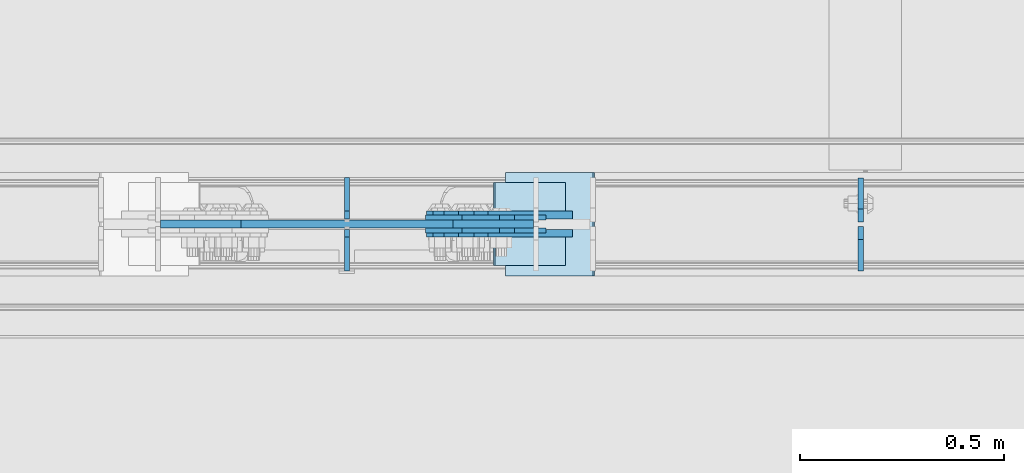
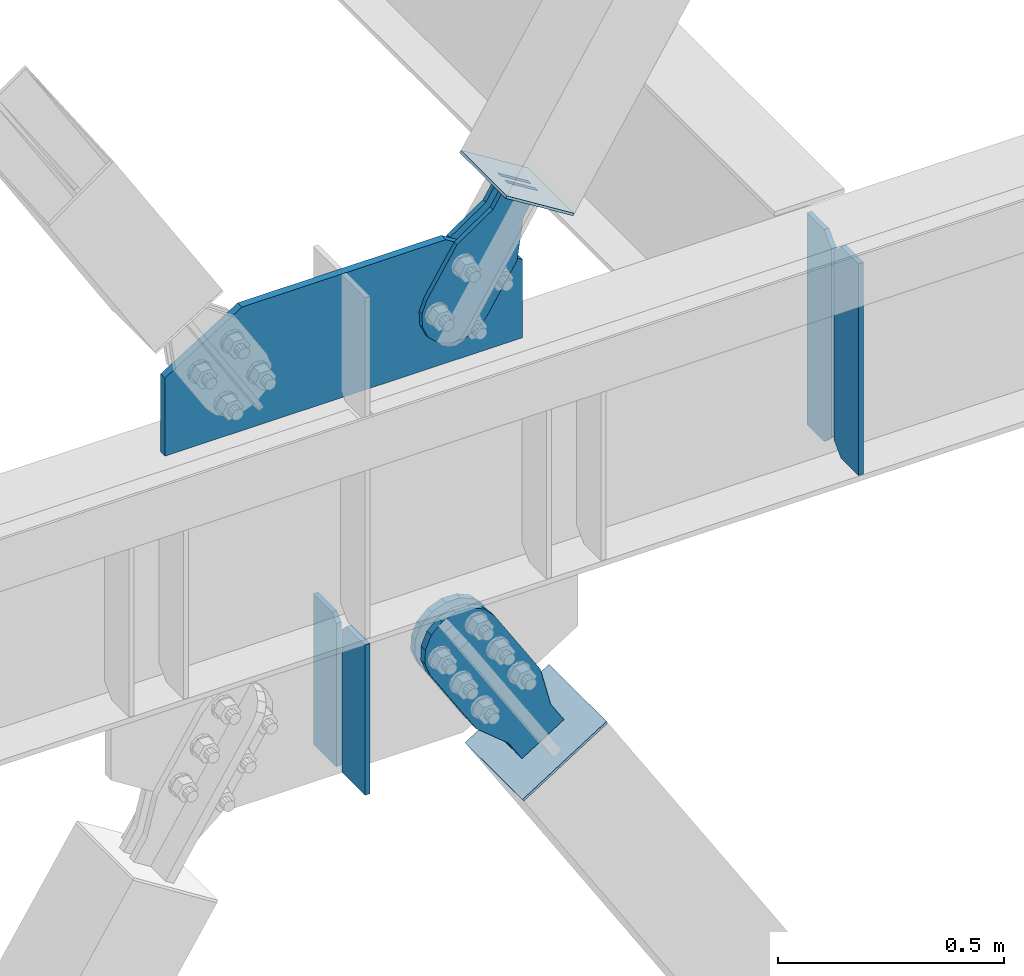
# One storey, part 3384 of 3843: 11 plates, 7 elements without a shape of their own.
"""IFC2X3 building model written with IfcOpenShell, lengths in millimetres."""

from ifc_helpers import new_model, si_unit, frame, origin_with_axes, place, context, subcontext, project, spatial, faceted_brep, material, type_object, element, aggregate, save


model = new_model("IFC2X3")

# Units and contexts
model_context = context("Model", 3, precision=1e-05, world=origin_with_axes())
body_context = subcontext(model_context, "Body", "Model", "MODEL_VIEW")
ifc_project = project(units=[si_unit("LENGTHUNIT", "METRE", prefix="MILLI"), si_unit("AREAUNIT", "SQUARE_METRE"), si_unit("VOLUMEUNIT", "CUBIC_METRE"), si_unit("MASSUNIT", "GRAM", prefix="KILO"), si_unit("TIMEUNIT", "SECOND"), si_unit("PLANEANGLEUNIT", "RADIAN"), si_unit("SOLIDANGLEUNIT", "STERADIAN"), si_unit("THERMODYNAMICTEMPERATUREUNIT", "DEGREE_CELSIUS"), si_unit("LUMINOUSINTENSITYUNIT", "LUMEN")], contexts=[model_context])

# Site, building, storey
site_placement = place(None, origin_with_axes())
site = spatial("IfcSite", under=ifc_project, at=site_placement, CompositionType="ELEMENT")
building_placement = place(site_placement, origin_with_axes())
building = spatial("IfcBuilding", under=site, at=building_placement, Name="Undefined", CompositionType="ELEMENT")
storey_placement = place(building_placement, origin_with_axes())
storey = spatial("IfcBuildingStorey", under=building, at=storey_placement, Name="Undefined", CompositionType="ELEMENT", Elevation=0.0)

# Assembly, plates
assembly_1_placement = place(storey_placement, origin_with_axes())
assembly_1 = element("IfcElementAssembly", 1, at=assembly_1_placement, inside=storey, Name="BEAM", AssemblyPlace="NOTDEFINED", PredefinedType="RIGID_FRAME")
ifc_material_1 = material(Name="STEEL/A572-50")
plate_type_1 = type_object("IfcPlateType", PredefinedType="NOTDEFINED")
plate_1_placement = place(assembly_1_placement, frame((27928.8874999046, 89110.34375, 35848.925), z_axis=(0.0, 0.0, 1.0), x_axis=(0.0, -1.0, 0.0)))
plate_1 = element("IfcPlate", 2, at=plate_1_placement, type_object=plate_type_1, material=ifc_material_1, Name="PLATE", context=body_context, shape_type="Brep", body=[
    faceted_brep([(0.0, -6.35000000000582, 31.75), (0.0, -6.34999999999854, 539.75), (0.0, 6.34999999999854, 539.75), (0.0, 6.35000000000582, 31.75), (31.75, -6.34999999999854, 571.5), (31.75, 6.34999999999854, 571.5), (108.743750000009, -6.34999999999854, 571.5), (108.743750000009, 6.34999999999854, 571.5), (108.743750000009, -6.34999999999854, 0.0), (108.743750000009, 6.34999999999854, 0.0), (31.75, -6.35000000000582, 0.0), (31.75, 6.35000000000582, 0.0)], [[[0, 1, 2, 3]], [[1, 4, 5, 2]], [[4, 6, 7, 5]], [[6, 8, 9, 7]], [[8, 10, 11, 9]], [[10, 0, 3, 11]], [[5, 7, 9, 11, 3, 2]], [[10, 8, 6, 4, 1, 0]]]),
])
plate_type_2 = type_object("IfcPlateType", PredefinedType="NOTDEFINED")
plate_2_placement = place(assembly_1_placement, frame((27928.8874999046, 89121.45625, 35848.925), z_axis=(0.0, 0.0, 1.0), x_axis=(0.0, 1.0, 0.0)))
plate_2 = element("IfcPlate", 3, at=plate_2_placement, type_object=plate_type_2, material=ifc_material_1, Name="PLATE", context=body_context, shape_type="Brep", body=[
    faceted_brep([(0.0, -6.35000000000582, 31.75), (0.0, -6.34999999999854, 539.75), (0.0, 6.34999999999854, 539.75), (0.0, 6.35000000000582, 31.75), (31.75, -6.34999999999854, 571.5), (31.75, 6.34999999999854, 571.5), (107.950000000012, -6.34999999999854, 571.5), (107.950000000012, 6.34999999999854, 571.5), (107.950000000012, -6.34999999999854, 0.0), (107.950000000012, 6.34999999999854, 0.0), (31.75, -6.35000000000582, 0.0), (31.75, 6.35000000000582, 0.0)], [[[0, 1, 2, 3]], [[1, 4, 5, 2]], [[4, 6, 7, 5]], [[6, 8, 9, 7]], [[8, 10, 11, 9]], [[10, 0, 3, 11]], [[5, 7, 9, 11, 3, 2]], [[10, 8, 6, 4, 1, 0]]]),
])
plate_type_3 = type_object("IfcPlateType", PredefinedType="NOTDEFINED")
plate_3_placement = place(assembly_1_placement, frame((26213.4822896351, 89115.9, 36436.3), z_axis=(1.0, 0.0, 0.0), x_axis=(0.0, 0.0, 1.0)))
plate_3 = element("IfcPlate", 4, at=plate_3_placement, type_object=plate_type_3, material=ifc_material_1, Name="CB", context=body_context, shape_type="Brep", body=[
    faceted_brep([(0.0, -9.52500000000146, 0.0), (-1.45519152283669e-11, -9.52499999997963, 913.035427129151), (2.91038304567337e-11, 9.52500000000873, 913.035427129151), (0.0, 9.52500000000146, 0.0), (210.595034109829, -9.52500000041618, 913.035427129151), (210.595034109872, 9.52499999957217, 913.035427129151), (333.366558250302, -9.52500000066357, 716.447524436167), (333.366558250345, 9.52499999933934, 716.447524436167), (333.366558250302, -9.52500000066357, 462.867713564574), (333.366558250345, 9.52499999933934, 462.867713564574), (333.366558250302, -9.52500000066357, 196.587902692983), (333.366558250345, 9.52499999933934, 196.587902692983), (210.595034109829, -9.52500000041618, 0.0), (210.595034109872, 9.52499999957217, 0.0)], [[[0, 1, 2, 3]], [[1, 4, 5, 2]], [[4, 6, 7, 5]], [[6, 8, 9, 7]], [[8, 10, 11, 9]], [[10, 12, 13, 11]], [[12, 0, 3, 13]], [[5, 7, 9, 11, 13, 3, 2]], [[12, 10, 8, 6, 4, 1, 0]]]),
])

# Assembly, plate
assembly_2_placement = place(storey_placement, origin_with_axes())
assembly_2 = element("IfcElementAssembly", 5, at=assembly_2_placement, inside=storey, AssemblyPlace="NOTDEFINED", PredefinedType="RIGID_FRAME")
ifc_material_2 = material(Name="STEEL/A36")
plate_type_4 = type_object("IfcPlateType", PredefinedType="NOTDEFINED")
plate_4_placement = place(assembly_2_placement, frame((27120.8876687841, 89131.7750061035, 36770.1963647805), z_axis=(-0.848184242744672, 0.0, 0.52970132184057), x_axis=(0.529701321840548, 0.0, 0.848184242744686)))
plate_4 = element("IfcPlate", 6, at=plate_4_placement, type_object=plate_type_4, material=ifc_material_2, context=body_context, shape_type="Brep", body=[
    faceted_brep([(0.0, -6.3499999046162, 0.0), (-101.599999999482, -6.35000000000582, -44.6881937832222), (-101.599999999482, 6.35000000000582, -44.6881937832222), (7.27595761418343e-12, 6.3499999046162, 0.0), (-246.684985846376, -6.35000000000582, -44.6881937832586), (-246.684985846376, 6.35000000000582, -44.6881937832586), (-281.313054100305, -6.35000000000582, -37.8002427490646), (-281.313054100305, 6.35000000000582, -37.8002427490646), (-310.669312866783, -6.35000000000582, -18.18501775197), (-310.669312866783, 6.35000000000582, -18.18501775197), (-330.284537863758, -6.35000000000582, 11.1712410146756), (-330.284537863758, 6.35000000000582, 11.1712410146756), (-337.172488897893, -6.35000000000582, 45.7993031645856), (-337.172488897893, 6.35000000000582, 45.7993031645856), (-330.284537863699, -6.35000000000582, 80.4273714186893), (-330.284537863699, 6.35000000000582, 80.4273714186893), (-310.669312866681, -6.35000000000582, 109.783630185331), (-310.669312866681, 6.35000000000582, 109.783630185331), (-281.313054100174, -6.35000000000582, 129.39885518244), (-281.313054100174, 6.35000000000582, 129.39885518244), (-246.684988898312, -6.35000000000582, 136.286806216667), (-246.684988898312, 6.35000000000582, 136.286806216667), (-101.599999999322, -6.35000000000582, 136.286806216689), (-101.599999999322, 6.35000000000582, 136.286806216689), (2.18278728425503e-10, -6.35000000000582, 91.5986124321353), (2.18278728425503e-10, 6.35000000000582, 91.5986124321353), (69.8499999987471, -6.35000000000582, 91.598612432037), (69.8499999987471, 6.35000000000582, 91.598612432037), (69.8499999985434, -6.35000000000582, -8.73114913702011e-11), (69.8499999985434, 6.35000000000582, -8.73114913702011e-11)], [[[0, 1, 2, 3]], [[1, 4, 5, 2]], [[4, 6, 7, 5]], [[6, 8, 9, 7]], [[8, 10, 11, 9]], [[10, 12, 13, 11]], [[12, 14, 15, 13]], [[14, 16, 17, 15]], [[16, 18, 19, 17]], [[18, 20, 21, 19]], [[20, 22, 23, 21]], [[22, 24, 25, 23]], [[24, 26, 27, 25]], [[26, 28, 29, 27]], [[28, 0, 3, 29]], [[5, 7, 9, 11, 13, 15, 17, 19, 21, 23, 25, 27, 29, 3, 2]], [[28, 26, 24, 22, 20, 18, 16, 14, 12, 10, 8, 6, 4, 1, 0]]]),
])
aggregate(assembly_2, [plate_4])

assembly_3_placement = place(storey_placement, origin_with_axes())
assembly_3 = element("IfcElementAssembly", 7, at=assembly_3_placement, inside=storey, AssemblyPlace="NOTDEFINED", PredefinedType="RIGID_FRAME")
plate_5_placement = place(assembly_3_placement, frame((27120.8876687841, 89100.0250061035, 36770.1963647805), z_axis=(-0.848184242744672, 0.0, 0.52970132184057), x_axis=(0.529701321840548, 0.0, 0.848184242744686)))
plate_5 = element("IfcPlate", 8, at=plate_5_placement, type_object=plate_type_4, material=ifc_material_2, context=body_context, shape_type="Brep", body=[
    faceted_brep([(0.0, -6.3499999046162, 0.0), (-101.599999999482, -6.35000000000582, -44.6881937832222), (-101.599999999482, 6.35000000000582, -44.6881937832222), (7.27595761418343e-12, 6.3499999046162, 0.0), (-246.684985846376, -6.35000000000582, -44.6881937832586), (-246.684985846376, 6.35000000000582, -44.6881937832586), (-281.313054100305, -6.35000000000582, -37.8002427490646), (-281.313054100305, 6.35000000000582, -37.8002427490646), (-310.669312866783, -6.35000000000582, -18.18501775197), (-310.669312866783, 6.35000000000582, -18.18501775197), (-330.284537863758, -6.35000000000582, 11.1712410146756), (-330.284537863758, 6.35000000000582, 11.1712410146756), (-337.172488897893, -6.35000000000582, 45.7993031645856), (-337.172488897893, 6.35000000000582, 45.7993031645856), (-330.284537863699, -6.35000000000582, 80.4273714186893), (-330.284537863699, 6.35000000000582, 80.4273714186893), (-310.669312866681, -6.35000000000582, 109.783630185331), (-310.669312866681, 6.35000000000582, 109.783630185331), (-281.313054100174, -6.35000000000582, 129.39885518244), (-281.313054100174, 6.35000000000582, 129.39885518244), (-246.684988898312, -6.35000000000582, 136.286806216667), (-246.684988898312, 6.35000000000582, 136.286806216667), (-101.599999999322, -6.35000000000582, 136.286806216689), (-101.599999999322, 6.35000000000582, 136.286806216689), (2.18278728425503e-10, -6.35000000000582, 91.5986124321353), (2.18278728425503e-10, 6.35000000000582, 91.5986124321353), (69.8499999987471, -6.35000000000582, 91.598612432037), (69.8499999987471, 6.35000000000582, 91.598612432037), (69.8499999985434, -6.35000000000582, -8.73114913702011e-11), (69.8499999985434, 6.35000000000582, -8.73114913702011e-11)], [[[0, 1, 2, 3]], [[1, 4, 5, 2]], [[4, 6, 7, 5]], [[6, 8, 9, 7]], [[8, 10, 11, 9]], [[10, 12, 13, 11]], [[12, 14, 15, 13]], [[14, 16, 17, 15]], [[16, 18, 19, 17]], [[18, 20, 21, 19]], [[20, 22, 23, 21]], [[22, 24, 25, 23]], [[24, 26, 27, 25]], [[26, 28, 29, 27]], [[28, 0, 3, 29]], [[5, 7, 9, 11, 13, 15, 17, 19, 21, 23, 25, 27, 29, 3, 2]], [[28, 26, 24, 22, 20, 18, 16, 14, 12, 10, 8, 6, 4, 1, 0]]]),
])
aggregate(assembly_3, [plate_5])

assembly_4_placement = place(storey_placement, origin_with_axes())
assembly_4 = element("IfcElementAssembly", 9, at=assembly_4_placement, inside=storey, Name="Plate", AssemblyPlace="NOTDEFINED", PredefinedType="RIGID_FRAME")
plate_type_5 = type_object("IfcPlateType", PredefinedType="NOTDEFINED")
plate_6_placement = place(assembly_4_placement, frame((27203.5347736152, 89014.3000061035, 36797.1913479082), z_axis=(-0.848184242744672, 0.0, 0.52970132184057), x_axis=(0.0, 1.0, 0.0)))
plate_6 = element("IfcPlate", 10, at=plate_6_placement, type_object=plate_type_5, material=ifc_material_2, Name="Plate", context=body_context, shape_type="Brep", body=[
    faceted_brep([(0.0, -3.17499999999927, 0.0), (0.0, -3.17500000043947, 203.200000001736), (0.0, 3.1749999995518, 203.200000001743), (0.0, 3.17499999999927, 0.0), (203.200000000012, -3.17500000043947, 203.200000001736), (203.200000000012, 3.1749999995518, 203.200000001743), (203.199996948242, -3.17499999999927, 0.0), (203.199996948242, 3.17499999999927, 0.0)], [[[0, 1, 2, 3]], [[1, 4, 5, 2]], [[4, 6, 7, 5]], [[6, 0, 3, 7]], [[5, 7, 3, 2]], [[6, 4, 1, 0]]]),
])
aggregate(assembly_4, [plate_6])

# Plate
plate_type_6 = type_object("IfcPlateType", PredefinedType="NOTDEFINED")
plate_7_placement = place(assembly_1_placement, frame((26670.0000031996, 89128.6, 35427.44375), z_axis=(0.0, 1.0, 0.0), x_axis=(0.0, 0.0, 1.0)))
plate_7 = element("IfcPlate", 11, at=plate_7_placement, type_object=plate_type_6, material=ifc_material_1, Name="CB", context=body_context, shape_type="Brep", body=[
    faceted_brep([(0.0, -6.3499999046162, 0.0), (-1.67347025126219e-10, -6.35000000000582, 101.600000000151), (-1.67347025126219e-10, 6.35000000000582, 101.600000000151), (7.27595761418343e-12, 6.3499999046162, 0.0), (405.541104201169, -6.34999999999854, 101.600000000006), (405.541104201169, 6.34999999999854, 101.600000000006), (405.541104201169, -6.34999999999854, 19.0499992370605), (405.541104201169, 6.34999999999854, 19.0499992370605), (386.491104964109, -6.34999999999854, 0.0), (386.491104964109, 6.34999999999854, 0.0)], [[[0, 1, 2, 3]], [[1, 4, 5, 2]], [[4, 6, 7, 5]], [[6, 8, 9, 7]], [[8, 0, 3, 9]], [[5, 7, 9, 3, 2]], [[8, 6, 4, 1, 0]]]),
])

plate_8_placement = place(assembly_1_placement, frame((26670.0000031996, 89103.2, 35427.44375), z_axis=(0.0, -1.0, 0.0), x_axis=(0.0, 0.0, 1.0)))
plate_8 = element("IfcPlate", 12, at=plate_8_placement, type_object=plate_type_6, material=ifc_material_1, Name="CB", context=body_context, shape_type="Brep", body=[
    faceted_brep([(0.0, -6.3499999046162, 0.0), (-1.67347025126219e-10, -6.35000000000582, 101.600000000151), (-1.67347025126219e-10, 6.35000000000582, 101.600000000151), (7.27595761418343e-12, 6.3499999046162, 0.0), (405.541104201169, -6.34999999999854, 101.600000000006), (405.541104201169, 6.34999999999854, 101.600000000006), (405.541104201169, -6.34999999999854, 19.0499992370605), (405.541104201169, 6.34999999999854, 19.0499992370605), (386.491104964109, -6.34999999999854, 0.0), (386.491104964109, 6.34999999999854, 0.0)], [[[0, 1, 2, 3]], [[1, 4, 5, 2]], [[4, 6, 7, 5]], [[6, 8, 9, 7]], [[8, 0, 3, 9]], [[5, 7, 9, 3, 2]], [[8, 6, 4, 1, 0]]]),
])

aggregate(assembly_1, [plate_1, plate_2, plate_3, plate_7, plate_8])

# Assembly, plate
assembly_5_placement = place(storey_placement, origin_with_axes())
assembly_5 = element("IfcElementAssembly", 13, at=assembly_5_placement, inside=storey, AssemblyPlace="NOTDEFINED", PredefinedType="RIGID_FRAME")
plate_type_7 = type_object("IfcPlateType", PredefinedType="NOTDEFINED")
plate_9_placement = place(assembly_5_placement, frame((27184.8354426622, 89138.1250061035, 35441.1491978489), z_axis=(-0.844597157113068, 0.0, -0.535402318071675), x_axis=(0.535402318071675, 0.0, -0.844597157113068)))
plate_9 = element("IfcPlate", 14, at=plate_9_placement, type_object=plate_type_7, material=ifc_material_2, context=body_context, shape_type="Brep", body=[
    faceted_brep([(0.0, -9.52500000000146, 0.0), (-101.599999996755, -9.52499999999418, -33.324272213511), (-101.599999996755, 9.52499999999418, -33.324272213511), (0.0, 9.52500000000146, 0.0), (-320.279297653902, -9.52499999999418, -33.3242722122595), (-320.279297653902, 9.52499999999418, -33.3242722122595), (-357.337405119242, -9.52499999999418, -25.9529563255783), (-357.337405119242, 9.52499999999418, -25.9529563255783), (-388.753751655597, -9.52499999999418, -4.96122468852991), (-388.753751655597, 9.52499999999418, -4.96122468852991), (-409.745483292782, -9.52499999999418, 26.4551218477136), (-409.745483292782, 9.52499999999418, 26.4551218477136), (-417.116799179586, -9.52499999999418, 63.5132262653569), (-417.116799179586, 9.52499999999418, 63.5132262653569), (-409.745483293211, -9.52499999999418, 100.57133373119), (-409.745483293211, 9.52499999999418, 100.57133373119), (-388.753751656006, -9.52499999999418, 131.987680267928), (-388.753751656006, 9.52499999999418, 131.987680267928), (-357.337405119271, -9.52499999999418, 152.97941190518), (-357.337405119271, 9.52499999999418, 152.97941190518), (-320.279299183247, -9.52499999999418, 160.350727791658), (-320.279299183247, 9.52499999999418, 160.350727791658), (-101.599999998418, -9.52499999999418, 160.350727790414), (-101.599999998418, 9.52499999999418, 160.350727790414), (-1.04046193882823e-09, -9.52499999999418, 127.02645557576), (-1.04046193882823e-09, 9.52499999999418, 127.02645557576), (69.8499999968899, -9.52499999999418, 127.026455575353), (69.8499999968899, 9.52499999999418, 127.026455575353), (69.8499999979995, -9.52499999999418, -4.00177668780088e-10), (69.8499999979995, 9.52499999999418, -4.00177668780088e-10)], [[[0, 1, 2, 3]], [[1, 4, 5, 2]], [[4, 6, 7, 5]], [[6, 8, 9, 7]], [[8, 10, 11, 9]], [[10, 12, 13, 11]], [[12, 14, 15, 13]], [[14, 16, 17, 15]], [[16, 18, 19, 17]], [[18, 20, 21, 19]], [[20, 22, 23, 21]], [[22, 24, 25, 23]], [[24, 26, 27, 25]], [[26, 28, 29, 27]], [[28, 0, 3, 29]], [[5, 7, 9, 11, 13, 15, 17, 19, 21, 23, 25, 27, 29, 3, 2]], [[28, 26, 24, 22, 20, 18, 16, 14, 12, 10, 8, 6, 4, 1, 0]]]),
])
aggregate(assembly_5, [plate_9])

assembly_6_placement = place(storey_placement, origin_with_axes())
assembly_6 = element("IfcElementAssembly", 15, at=assembly_6_placement, inside=storey, AssemblyPlace="NOTDEFINED", PredefinedType="RIGID_FRAME")
plate_10_placement = place(assembly_6_placement, frame((27184.8354426622, 89093.6750061035, 35441.1491978489), z_axis=(-0.844597157113068, 0.0, -0.535402318071675), x_axis=(0.535402318071675, 0.0, -0.844597157113068)))
plate_10 = element("IfcPlate", 16, at=plate_10_placement, type_object=plate_type_7, material=ifc_material_2, context=body_context, shape_type="Brep", body=[
    faceted_brep([(0.0, -9.52500000000146, 0.0), (-101.599999996755, -9.52499999999418, -33.324272213511), (-101.599999996755, 9.52499999999418, -33.324272213511), (0.0, 9.52500000000146, 0.0), (-320.279297653902, -9.52499999999418, -33.3242722122595), (-320.279297653902, 9.52499999999418, -33.3242722122595), (-357.337405119242, -9.52499999999418, -25.9529563255783), (-357.337405119242, 9.52499999999418, -25.9529563255783), (-388.753751655597, -9.52499999999418, -4.96122468852991), (-388.753751655597, 9.52499999999418, -4.96122468852991), (-409.745483292782, -9.52499999999418, 26.4551218477136), (-409.745483292782, 9.52499999999418, 26.4551218477136), (-417.116799179586, -9.52499999999418, 63.5132262653569), (-417.116799179586, 9.52499999999418, 63.5132262653569), (-409.745483293211, -9.52499999999418, 100.57133373119), (-409.745483293211, 9.52499999999418, 100.57133373119), (-388.753751656006, -9.52499999999418, 131.987680267928), (-388.753751656006, 9.52499999999418, 131.987680267928), (-357.337405119271, -9.52499999999418, 152.97941190518), (-357.337405119271, 9.52499999999418, 152.97941190518), (-320.279299183247, -9.52499999999418, 160.350727791658), (-320.279299183247, 9.52499999999418, 160.350727791658), (-101.599999998418, -9.52499999999418, 160.350727790414), (-101.599999998418, 9.52499999999418, 160.350727790414), (-1.04046193882823e-09, -9.52499999999418, 127.02645557576), (-1.04046193882823e-09, 9.52499999999418, 127.02645557576), (69.8499999968899, -9.52499999999418, 127.026455575353), (69.8499999968899, 9.52499999999418, 127.026455575353), (69.8499999979995, -9.52499999999418, -4.00177668780088e-10), (69.8499999979995, 9.52499999999418, -4.00177668780088e-10)], [[[0, 1, 2, 3]], [[1, 4, 5, 2]], [[4, 6, 7, 5]], [[6, 8, 9, 7]], [[8, 10, 11, 9]], [[10, 12, 13, 11]], [[12, 14, 15, 13]], [[14, 16, 17, 15]], [[16, 18, 19, 17]], [[18, 20, 21, 19]], [[20, 22, 23, 21]], [[22, 24, 25, 23]], [[24, 26, 27, 25]], [[26, 28, 29, 27]], [[28, 0, 3, 29]], [[5, 7, 9, 11, 13, 15, 17, 19, 21, 23, 25, 27, 29, 3, 2]], [[28, 26, 24, 22, 20, 18, 16, 14, 12, 10, 8, 6, 4, 1, 0]]]),
])
aggregate(assembly_6, [plate_10])

assembly_7_placement = place(storey_placement, origin_with_axes())
assembly_7 = element("IfcElementAssembly", 17, at=assembly_7_placement, inside=storey, Name="Plate", AssemblyPlace="NOTDEFINED", PredefinedType="RIGID_FRAME")
plate_type_8 = type_object("IfcPlateType", PredefinedType="NOTDEFINED")
plate_11_placement = place(assembly_7_placement, frame((27059.6264616418, 89242.9000061035, 35282.8344586137), z_axis=(0.844597157113068, 0.0, 0.535402318071675), x_axis=(0.0, -1.0, 0.0)))
plate_11 = element("IfcPlate", 18, at=plate_11_placement, type_object=plate_type_8, material=ifc_material_2, Name="Plate", context=body_context, shape_type="Brep", body=[
    faceted_brep([(0.0, -3.17499999999927, 0.0), (0.0, -3.17499999965185, 254.000000005151), (0.0, 3.17500000035216, 254.000000005166), (0.0, 3.17499999999927, 0.0), (254.0, -3.17499999965185, 254.000000005151), (254.0, 3.17500000035216, 254.000000005166), (254.0, -3.17500000000291, 0.0), (254.0, 3.17499999999927, 1.45519152283669e-11)], [[[0, 1, 2, 3]], [[1, 4, 5, 2]], [[4, 6, 7, 5]], [[6, 0, 3, 7]], [[5, 7, 3, 2]], [[6, 4, 1, 0]]]),
])
aggregate(assembly_7, [plate_11])

save(model, "model.ifc")
